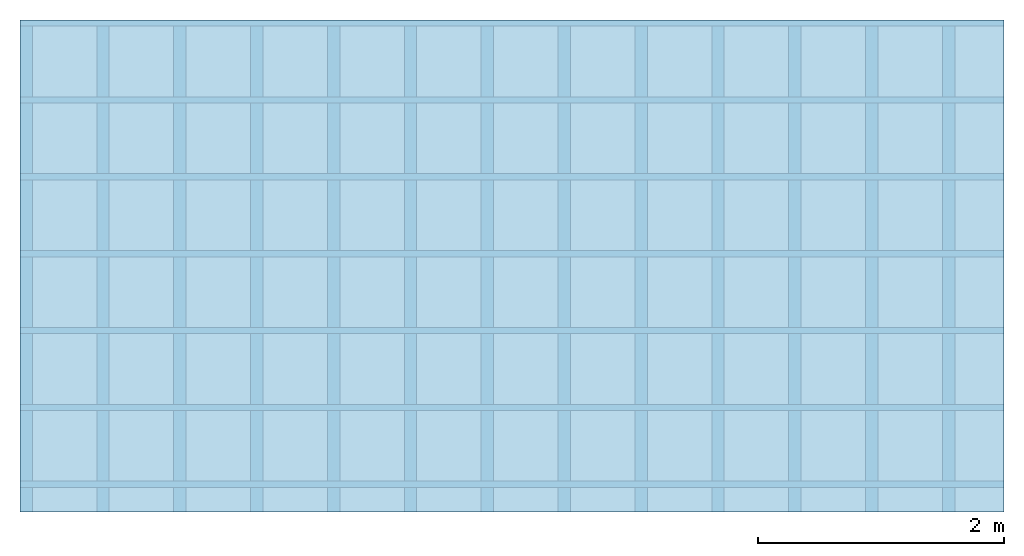
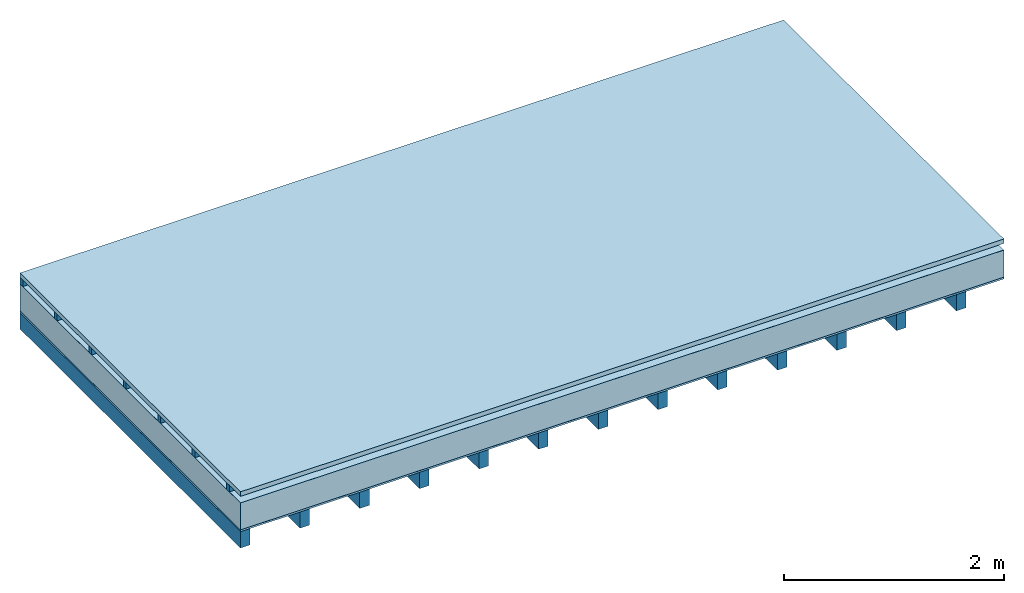
# One storey: 5 plates, 2 members, 1 element without a shape of its own.
"""IFC4 building model written with IfcOpenShell, lengths in metres."""

from ifc_helpers import new_model, si_unit, derived_unit, direction, frame, frame_2d, origin, origin_with_axes, place, context, project, spatial, rectangle, extrude, material, layer, layer_set, type_object, element, aggregate, save


model = new_model("IFC4")

# Units and contexts
plan_context = context("Plan", 3, precision=1e-05, world=origin(), true_north=direction((0.0, 1.0)))
model_context = context("Model", 3, precision=1e-05, world=origin(), true_north=direction((0.0, 1.0)))
ifc_project = project(units=[si_unit("LENGTHUNIT", "METRE"), derived_unit("SOUNDPRESSUREUNIT", [(si_unit("PRESSUREUNIT", "PASCAL", prefix="MICRO"), 0)]), si_unit("ENERGYUNIT", "JOULE", prefix="MEGA"), si_unit("MASSUNIT", "GRAM", prefix="KILO"), derived_unit("THERMALTRANSMITTANCEUNIT", [(si_unit("POWERUNIT", "WATT"), 1), (si_unit("AREAUNIT", "SQUARE_METRE"), -1), (si_unit("THERMODYNAMICTEMPERATUREUNIT", "KELVIN"), -1)]), derived_unit("AREADENSITYUNIT", [(si_unit("MASSUNIT", "GRAM", prefix="KILO"), 1), (si_unit("AREAUNIT", "SQUARE_METRE"), -1)]), derived_unit("USERDEFINED", [(si_unit("ENERGYUNIT", "JOULE", prefix="MEGA"), 1), (si_unit("AREAUNIT", "SQUARE_METRE"), -1)])], contexts=[plan_context, model_context])

# Site, building, storey
site = spatial("IfcSite", under=ifc_project)
building_placement = place(None, origin())
building = spatial("IfcBuilding", under=site, at=building_placement)
storey_placement = place(building_placement, origin())
storey = spatial("IfcBuildingStorey", under=building, at=storey_placement)

# Slab, members, plates
ifc_material_1 = material(Name="Roof tiles", Category="03.015")
ifc_layer_1 = layer(ifc_material_1, 0.05, Name="Roofing")
ifc_layer_2 = layer(None, 0.072, Name="Battens / profiles")
ifc_material_2 = material(Name="Roofing underlay", Category="09.008")
ifc_layer_3 = layer(ifc_material_2, 0.00018, Name="Under the roof")
ifc_material_3 = material(Category="10.009")
ifc_layer_4 = layer(ifc_material_3, 0.3, Name="Exterior insulation layer 1")
ifc_material_4 = material(Name="Vapor barrier polyethylene (PE)", Category="09.002")
ifc_layer_5 = layer(ifc_material_4, 0.00018, Name="above 1st layer")
ifc_material_5 = material(Name="Boards with edges", Category="07.009")
ifc_layer_6 = layer(ifc_material_5, 0.02, Name="Sub-floor")
ifc_material_6 = material(Name="of the art")
ifc_layer_7 = layer(ifc_material_6, 0.0, Name="Bond")
ifc_layer_8 = layer(None, 0.18, Name="Supporting structure")
ifc_layer_set = layer_set([ifc_layer_1, ifc_layer_2, ifc_layer_3, ifc_layer_4, ifc_layer_5, ifc_layer_6, ifc_layer_7, ifc_layer_8])
slab_type = type_object("IfcSlabType", Name="E0175", PredefinedType="NOTDEFINED", material=ifc_layer_set)
slab_placement = place(None, frame((0.0, 0.0, 0.0), z_axis=(0.0, 0.0, -1.0), x_axis=(1.0, 0.0, 0.0)))
slab = element("IfcSlab", 1, at=slab_placement, inside=storey, type_object=slab_type, material=ifc_layer_set, Name="Slab #1")
ifc_material_7 = material()
member_1_placement = place(slab_placement, origin())
member_1 = element("IfcMember", 2, at=member_1_placement, material=ifc_material_7, Name="Battens / profiles", context=plan_context, shape_type="SweptSolid", body=[
    extrude(rectangle(XDim=0.05, YDim=0.072, at=frame_2d((0.025, 0.036), x_axis=(1.0, 0.0))), frame((0.0, 0.0, 0.05), z_axis=(1.0, 0.0, 0.0), x_axis=(0.0, 1.0, 0.0)), (0.0, 0.0, 1.0), 8.0),
    extrude(rectangle(XDim=0.05, YDim=0.072, at=frame_2d((0.025, 0.036), x_axis=(1.0, 0.0))), frame((0.0, 0.625, 0.05), z_axis=(1.0, 0.0, 0.0), x_axis=(0.0, 1.0, 0.0)), (0.0, 0.0, 1.0), 8.0),
    extrude(rectangle(XDim=0.05, YDim=0.072, at=frame_2d((0.025, 0.036), x_axis=(1.0, 0.0))), frame((0.0, 1.25, 0.05), z_axis=(1.0, 0.0, 0.0), x_axis=(0.0, 1.0, 0.0)), (0.0, 0.0, 1.0), 8.0),
    extrude(rectangle(XDim=0.05, YDim=0.072, at=frame_2d((0.025, 0.036), x_axis=(1.0, 0.0))), frame((0.0, 1.875, 0.05), z_axis=(1.0, 0.0, 0.0), x_axis=(0.0, 1.0, 0.0)), (0.0, 0.0, 1.0), 8.0),
    extrude(rectangle(XDim=0.05, YDim=0.072, at=frame_2d((0.025, 0.036), x_axis=(1.0, 0.0))), frame((0.0, 2.5, 0.05), z_axis=(1.0, 0.0, 0.0), x_axis=(0.0, 1.0, 0.0)), (0.0, 0.0, 1.0), 8.0),
    extrude(rectangle(XDim=0.05, YDim=0.072, at=frame_2d((0.025, 0.036), x_axis=(1.0, 0.0))), frame((0.0, 3.125, 0.05), z_axis=(1.0, 0.0, 0.0), x_axis=(0.0, 1.0, 0.0)), (0.0, 0.0, 1.0), 8.0),
    extrude(rectangle(XDim=0.05, YDim=0.072, at=frame_2d((0.025, 0.036), x_axis=(1.0, 0.0))), frame((0.0, 3.75, 0.05), z_axis=(1.0, 0.0, 0.0), x_axis=(0.0, 1.0, 0.0)), (0.0, 0.0, 1.0), 8.0),
])
ifc_material_8 = material()
member_2_placement = place(slab_placement, origin())
member_2 = element("IfcMember", 3, at=member_2_placement, material=ifc_material_8, Name="Supporting structure", context=plan_context, shape_type="SweptSolid", body=[
    extrude(rectangle(XDim=0.1, YDim=0.18, at=frame_2d((0.05, 0.09), x_axis=(1.0, 0.0))), frame((0.0, 4.0, 0.44236), z_axis=(0.0, -1.0, 0.0), x_axis=(1.0, 0.0, 0.0)), (0.0, 0.0, 1.0), 4.0),
    extrude(rectangle(XDim=0.1, YDim=0.18, at=frame_2d((0.05, 0.09), x_axis=(1.0, 0.0))), frame((0.625, 4.0, 0.44236), z_axis=(0.0, -1.0, 0.0), x_axis=(1.0, 0.0, 0.0)), (0.0, 0.0, 1.0), 4.0),
    extrude(rectangle(XDim=0.1, YDim=0.18, at=frame_2d((0.05, 0.09), x_axis=(1.0, 0.0))), frame((1.25, 4.0, 0.44236), z_axis=(0.0, -1.0, 0.0), x_axis=(1.0, 0.0, 0.0)), (0.0, 0.0, 1.0), 4.0),
    extrude(rectangle(XDim=0.1, YDim=0.18, at=frame_2d((0.05, 0.09), x_axis=(1.0, 0.0))), frame((1.875, 4.0, 0.44236), z_axis=(0.0, -1.0, 0.0), x_axis=(1.0, 0.0, 0.0)), (0.0, 0.0, 1.0), 4.0),
    extrude(rectangle(XDim=0.1, YDim=0.18, at=frame_2d((0.05, 0.09), x_axis=(1.0, 0.0))), frame((2.5, 4.0, 0.44236), z_axis=(0.0, -1.0, 0.0), x_axis=(1.0, 0.0, 0.0)), (0.0, 0.0, 1.0), 4.0),
    extrude(rectangle(XDim=0.1, YDim=0.18, at=frame_2d((0.05, 0.09), x_axis=(1.0, 0.0))), frame((3.125, 4.0, 0.44236), z_axis=(0.0, -1.0, 0.0), x_axis=(1.0, 0.0, 0.0)), (0.0, 0.0, 1.0), 4.0),
    extrude(rectangle(XDim=0.1, YDim=0.18, at=frame_2d((0.05, 0.09), x_axis=(1.0, 0.0))), frame((3.75, 4.0, 0.44236), z_axis=(0.0, -1.0, 0.0), x_axis=(1.0, 0.0, 0.0)), (0.0, 0.0, 1.0), 4.0),
    extrude(rectangle(XDim=0.1, YDim=0.18, at=frame_2d((0.05, 0.09), x_axis=(1.0, 0.0))), frame((4.375, 4.0, 0.44236), z_axis=(0.0, -1.0, 0.0), x_axis=(1.0, 0.0, 0.0)), (0.0, 0.0, 1.0), 4.0),
    extrude(rectangle(XDim=0.1, YDim=0.18, at=frame_2d((0.05, 0.09), x_axis=(1.0, 0.0))), frame((5.0, 4.0, 0.44236), z_axis=(0.0, -1.0, 0.0), x_axis=(1.0, 0.0, 0.0)), (0.0, 0.0, 1.0), 4.0),
    extrude(rectangle(XDim=0.1, YDim=0.18, at=frame_2d((0.05, 0.09), x_axis=(1.0, 0.0))), frame((5.625, 4.0, 0.44236), z_axis=(0.0, -1.0, 0.0), x_axis=(1.0, 0.0, 0.0)), (0.0, 0.0, 1.0), 4.0),
    extrude(rectangle(XDim=0.1, YDim=0.18, at=frame_2d((0.05, 0.09), x_axis=(1.0, 0.0))), frame((6.25, 4.0, 0.44236), z_axis=(0.0, -1.0, 0.0), x_axis=(1.0, 0.0, 0.0)), (0.0, 0.0, 1.0), 4.0),
    extrude(rectangle(XDim=0.1, YDim=0.18, at=frame_2d((0.05, 0.09), x_axis=(1.0, 0.0))), frame((6.875, 4.0, 0.44236), z_axis=(0.0, -1.0, 0.0), x_axis=(1.0, 0.0, 0.0)), (0.0, 0.0, 1.0), 4.0),
    extrude(rectangle(XDim=0.1, YDim=0.18, at=frame_2d((0.05, 0.09), x_axis=(1.0, 0.0))), frame((7.5, 4.0, 0.44236), z_axis=(0.0, -1.0, 0.0), x_axis=(1.0, 0.0, 0.0)), (0.0, 0.0, 1.0), 4.0),
])
plate_1_placement = place(slab_placement, origin())
plate_1 = element("IfcPlate", 4, at=plate_1_placement, material=ifc_material_1, Name="Roofing", context=plan_context, shape_type="SweptSolid", body=[
    extrude(rectangle(XDim=8.0, YDim=4.0, at=frame_2d((4.0, 2.0), x_axis=(1.0, 0.0))), origin_with_axes(), (0.0, 0.0, 1.0), 0.05),
])
plate_2_placement = place(slab_placement, origin())
plate_2 = element("IfcPlate", 5, at=plate_2_placement, material=ifc_material_2, Name="Under the roof", context=plan_context, shape_type="SweptSolid", body=[
    extrude(rectangle(XDim=8.0, YDim=4.0, at=frame_2d((4.0, 2.0), x_axis=(1.0, 0.0))), frame((0.0, 0.0, 0.122), z_axis=(0.0, 0.0, 1.0), x_axis=(1.0, 0.0, 0.0)), (0.0, 0.0, 1.0), 0.00018),
])
plate_3_placement = place(slab_placement, origin())
plate_3 = element("IfcPlate", 6, at=plate_3_placement, material=ifc_material_3, Name="Exterior insulation layer 1", context=plan_context, shape_type="SweptSolid", body=[
    extrude(rectangle(XDim=8.0, YDim=4.0, at=frame_2d((4.0, 2.0), x_axis=(1.0, 0.0))), frame((0.0, 0.0, 0.12218), z_axis=(0.0, 0.0, 1.0), x_axis=(1.0, 0.0, 0.0)), (0.0, 0.0, 1.0), 0.3),
])
plate_4_placement = place(slab_placement, origin())
plate_4 = element("IfcPlate", 7, at=plate_4_placement, material=ifc_material_4, Name="above 1st layer", context=plan_context, shape_type="SweptSolid", body=[
    extrude(rectangle(XDim=8.0, YDim=4.0, at=frame_2d((4.0, 2.0), x_axis=(1.0, 0.0))), frame((0.0, 0.0, 0.42218), z_axis=(0.0, 0.0, 1.0), x_axis=(1.0, 0.0, 0.0)), (0.0, 0.0, 1.0), 0.00018),
])
plate_5_placement = place(slab_placement, origin())
plate_5 = element("IfcPlate", 8, at=plate_5_placement, material=ifc_material_5, Name="Sub-floor", context=plan_context, shape_type="SweptSolid", body=[
    extrude(rectangle(XDim=8.0, YDim=4.0, at=frame_2d((4.0, 2.0), x_axis=(1.0, 0.0))), frame((0.0, 0.0, 0.42236), z_axis=(0.0, 0.0, 1.0), x_axis=(1.0, 0.0, 0.0)), (0.0, 0.0, 1.0), 0.02),
])
aggregate(slab, [plate_1, member_1, plate_2, plate_3, plate_4, plate_5, member_2])

save(model, "model.ifc")
